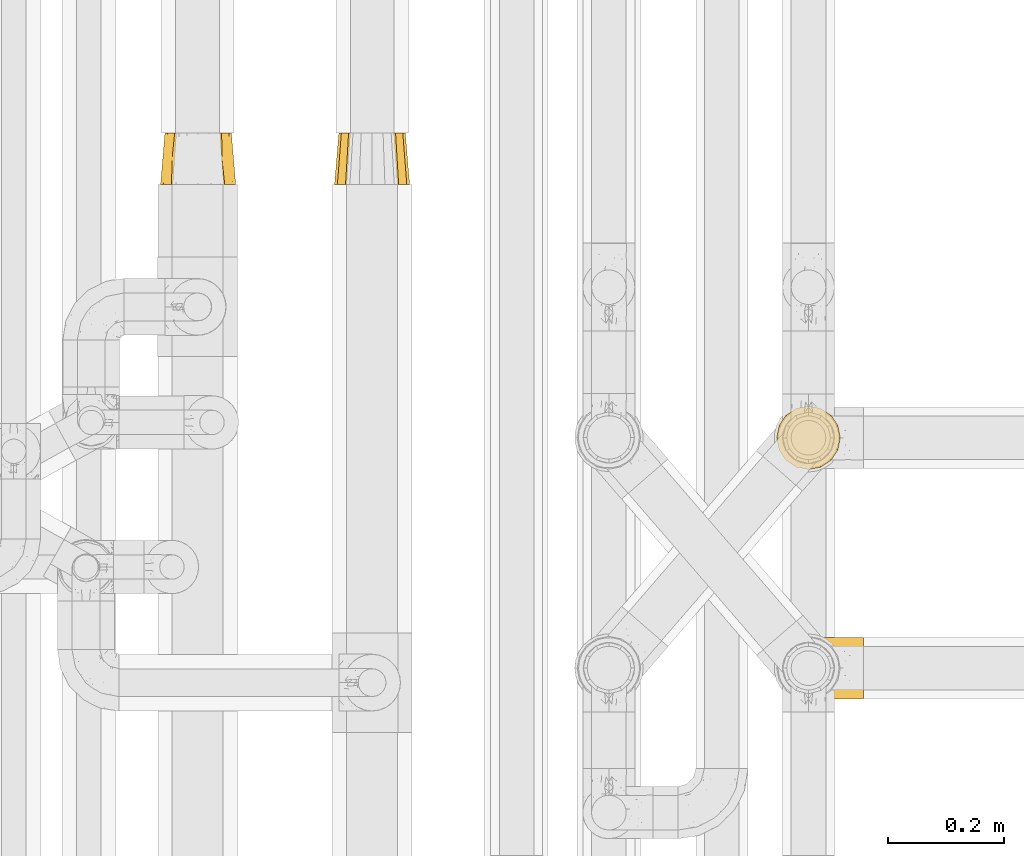
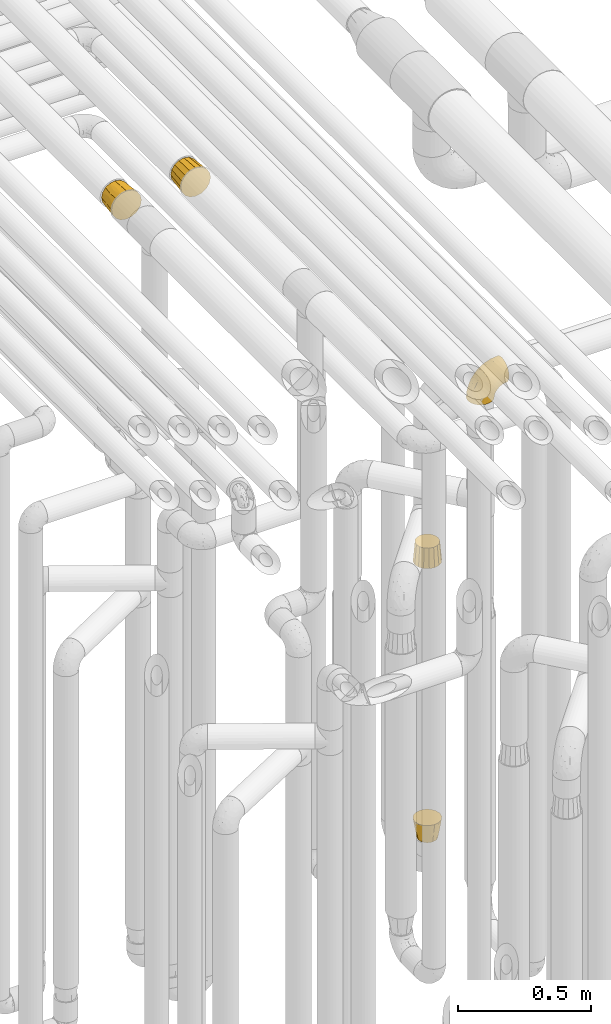
# One storey, part 233 of 827: 5 coverings.
"""IFC2X3 building model written with IfcOpenShell, lengths in millimetres."""

import ifcopenshell
import ifcopenshell.guid

model = None  # the IFC model being written
_history = None  # IfcOwnerHistory: only IFC2X3 demands one
_inside = {}  # id of a spatial element -> (the spatial element, [elements in it])
_under = {}  # id of a project, library or spatial element -> (it, [spatial elements below it])
_declared = {}  # id of a project -> (the project, [libraries it declares])
_typed = {}  # id of a type object -> (the type object, [elements of that type])
_made_of = {}  # id of a material, layer set ... -> (it, [elements and type objects made of it])


def new_model(schema):
    """Start an empty IFC model of exactly this schema.

    Asked for "IFC4X3", IfcOpenShell would pick the latest addendum, in which some entities
    have other attributes; the version numbers below select the first issue.
    IFC2X3 requires an IfcOwnerHistory on every rooted entity: one is made here for all.
    """
    global model, _history
    if schema == "IFC4X3":
        model = ifcopenshell.file(schema_version=(4, 3, 0, 0))
    else:
        model = ifcopenshell.file(schema=schema)
    _inside.clear()
    _under.clear()
    _declared.clear()
    _typed.clear()
    _made_of.clear()
    _history = None
    if model.schema == "IFC2X3":
        org = make("IfcOrganization", Name="unknown")
        user = make(
            "IfcPersonAndOrganization",
            ThePerson=make("IfcPerson", FamilyName="unknown"),
            TheOrganization=org,
        )
        app = make(
            "IfcApplication",
            ApplicationDeveloper=org,
            Version="unknown",
            ApplicationFullName="unknown",
            ApplicationIdentifier="unknown",
        )
        _history = make(
            "IfcOwnerHistory",
            OwningUser=user,
            OwningApplication=app,
            ChangeAction="ADDED",
            CreationDate=0,
        )
    return model


def make(cls, **values):
    """One entity of the class cls with the attributes given. An attribute that is None is left unset."""
    return model.create_entity(
        cls, **{name: value for name, value in values.items() if value is not None}
    )


def entity(cls, *values):
    """Any entity or typed value of the class cls, its attributes in the order of the schema. None: left unset."""
    e = model.create_entity(cls)
    for i, value in enumerate(values):
        if value is not None:
            e[i] = value
    return e


def rooted(cls, **values):
    """An entity with a GlobalId (a new one), such as an element, a storey or a relation."""
    return make(cls, GlobalId=ifcopenshell.guid.new(), OwnerHistory=_history, **values)


def si_unit(unit_type, name, prefix=None):
    """IfcSIUnit, for example si_unit("LENGTHUNIT", "METRE", prefix="MILLI")."""
    return make("IfcSIUnit", UnitType=unit_type, Prefix=prefix, Name=name)


def converted_unit(unit_type, name, factor, base, dimensions=None, offset=None):
    """IfcConversionBasedUnit, such as the inch: factor (a typed value) times the base unit."""
    return make(
        "IfcConversionBasedUnit"
        if offset is None
        else "IfcConversionBasedUnitWithOffset",
        ConversionOffset=offset,
        Dimensions=None
        if dimensions is None
        else entity("IfcDimensionalExponents", *dimensions),
        UnitType=unit_type,
        Name=name,
        ConversionFactor=make(
            "IfcMeasureWithUnit", ValueComponent=factor, UnitComponent=base
        ),
    )


def derived_unit(unit_type, elements):
    """IfcDerivedUnit: a product of units, each with its exponent."""
    return make(
        "IfcDerivedUnit",
        Elements=[
            make("IfcDerivedUnitElement", Unit=unit, Exponent=power)
            for unit, power in elements
        ],
        UnitType=unit_type,
    )


def assignment(units):
    """IfcUnitAssignment: the units of a project."""
    return None if units is None else make("IfcUnitAssignment", Units=units)


def point(xyz):
    """IfcCartesianPoint."""
    return None if xyz is None else make("IfcCartesianPoint", Coordinates=xyz)


def direction(xyz):
    """IfcDirection."""
    return None if xyz is None else make("IfcDirection", DirectionRatios=xyz)


def frame(location, z_axis=None, x_axis=None):
    """IfcAxis2Placement3D, a coordinate frame: its origin and axes. An axis left out is left unset."""
    return make(
        "IfcAxis2Placement3D",
        Location=point(location),
        Axis=direction(z_axis),
        RefDirection=direction(x_axis),
    )


def origin():
    """The frame at (0, 0, 0) with its axes left unset."""
    return frame((0.0, 0.0, 0.0))


def place(relative_to, where):
    """IfcLocalPlacement: puts the frame where relative to a parent placement (None: the world)."""
    return make(
        "IfcLocalPlacement", PlacementRelTo=relative_to, RelativePlacement=where
    )


def context(
    kind, dimensions, precision=None, world=None, true_north=None, identifier=None
):
    """IfcGeometricRepresentationContext, for example the 3D "Model" context."""
    return make(
        "IfcGeometricRepresentationContext",
        ContextIdentifier=identifier,
        ContextType=kind,
        CoordinateSpaceDimension=dimensions,
        Precision=precision,
        WorldCoordinateSystem=world,
        TrueNorth=true_north,
    )


def subcontext(parent, identifier, kind, view, scale=None):
    """IfcGeometricRepresentationSubContext, for example "Body" below "Model"."""
    return make(
        "IfcGeometricRepresentationSubContext",
        ContextIdentifier=identifier,
        ContextType=kind,
        ParentContext=parent,
        TargetScale=scale,
        TargetView=view,
    )


def project(units=None, contexts=None):
    """IfcProject with its units and contexts."""
    return rooted(
        "IfcProject",
        Name="project",
        RepresentationContexts=contexts,
        UnitsInContext=assignment(units),
    )


def spatial(cls, under=None, at=None, **own):
    """A site, building, storey or space (cls), placed at a placement, below another one or the project."""
    s = rooted(cls, ObjectPlacement=at, **own)
    if under is not None:
        _under.setdefault(under.id(), (under, []))[1].append(s)
    return s


def faces_of(points, faces, orient=None, outer=None):
    """IfcFace entities. A face is a list of loops; a loop is a list of indices into points, from 0.

    orient and outer hold one flag for each loop. By default every Orientation is true, the
    first loop of a face is its IfcFaceOuterBound and the others are IfcFaceBound.
    """
    made = []
    for i, loops in enumerate(faces):
        bounds = []
        for j, loop in enumerate(loops):
            is_outer = j == 0 if outer is None else outer[i][j]
            bounds.append(
                make(
                    "IfcFaceOuterBound" if is_outer else "IfcFaceBound",
                    Bound=make("IfcPolyLoop", Polygon=[points[k] for k in loop]),
                    Orientation=True if orient is None else orient[i][j],
                )
            )
        made.append(make("IfcFace", Bounds=bounds))
    return made


def faceted_brep(points, faces, orient=None, outer=None, voids=None):
    """IfcFacetedBrep: a solid bounded by flat faces; with voids (closed shells), ...WithVoids."""
    shared = [point(p) for p in points]
    hull = make("IfcClosedShell", CfsFaces=faces_of(shared, faces, orient, outer))
    if voids is None:
        return make("IfcFacetedBrep", Outer=hull)
    return make(
        "IfcFacetedBrepWithVoids",
        Outer=hull,
        Voids=[
            make(cls, CfsFaces=faces_of(shared, fs, o, b)) for cls, fs, o, b in voids
        ],
    )


def shape(context_of_items, identifier, shape_type, items):
    """IfcShapeRepresentation: the items that make up one representation, for example the "Body"."""
    return make(
        "IfcShapeRepresentation",
        ContextOfItems=context_of_items,
        RepresentationIdentifier=identifier,
        RepresentationType=shape_type,
        Items=items,
    )


def made_of(thing, what):
    """Note that an element or type object is made of a material, layer set ...; save() writes the relation."""
    if what is not None:
        _made_of.setdefault(what.id(), (what, []))[1].append(thing)
    return thing


def element(
    cls,
    number,
    at=None,
    inside=None,
    cuts=None,
    type_object=None,
    material=None,
    context=None,
    identifier="Body",
    shape_type=None,
    held_by="IfcProductDefinitionShape",
    body=None,
    shapes=None,
    **own,
):
    """One element of the class cls, such as IfcWall. Its Tag is "e" and its number.

    at: its placement. inside: the storey or other place that contains it. cuts: it is an
    opening in that element (IfcRelVoidsElement). A single representation is given by context,
    identifier, shape_type and body (its items); several are given by shapes. held_by: the class
    of the entity that holds the representations. save() writes the other relations.
    """
    e = rooted(cls, Tag="e%d" % number, ObjectPlacement=at, **own)
    if body is not None:
        shapes = [shape(context, identifier, shape_type, body)]
    if shapes is not None:
        e.Representation = make(held_by, Representations=shapes)
    if inside is not None:
        _inside.setdefault(inside.id(), (inside, []))[1].append(e)
    if cuts is not None:
        rooted(
            "IfcRelVoidsElement", RelatingBuildingElement=cuts, RelatedOpeningElement=e
        )
    if type_object is not None:
        _typed.setdefault(type_object.id(), (type_object, []))[1].append(e)
    return made_of(e, material)


def aggregate(whole, parts):
    """IfcRelAggregates: a whole, such as a stair, and the parts it consists of."""
    return rooted("IfcRelAggregates", RelatingObject=whole, RelatedObjects=parts)


def save(model, path):
    """Write the relations noted so far, then the file.

    IfcRelAggregates (storeys below a building ...), IfcRelContainedInSpatialStructure (elements
    in a storey), IfcRelDefinesByType, IfcRelAssociatesMaterial and IfcRelDeclares: one each for
    every whole, place, type object, material and project.
    """
    for whole, parts in _under.values():
        aggregate(whole, parts)
    for where, things in _inside.values():
        rooted(
            "IfcRelContainedInSpatialStructure",
            RelatedElements=things,
            RelatingStructure=where,
        )
    for kind, things in _typed.values():
        rooted("IfcRelDefinesByType", RelatedObjects=things, RelatingType=kind)
    for what, things in _made_of.values():
        rooted("IfcRelAssociatesMaterial", RelatedObjects=things, RelatingMaterial=what)
    for by, libraries in _declared.values():
        rooted("IfcRelDeclares", RelatingContext=by, RelatedDefinitions=libraries)
    model.write(path)


model = new_model("IFC2X3")

# Units and contexts
model_context = context("Model", 3, precision=0.01, world=origin(), true_north=direction((6.12303176911189e-17, 1.0)))
body_context = subcontext(model_context, "Body", "Model", "MODEL_VIEW")
ifc_project = project(units=[si_unit("LENGTHUNIT", "METRE", prefix="MILLI"), si_unit("AREAUNIT", "SQUARE_METRE"), si_unit("VOLUMEUNIT", "CUBIC_METRE"), converted_unit("PLANEANGLEUNIT", "DEGREE", entity("IfcRatioMeasure", 0.0174532925199433), si_unit("PLANEANGLEUNIT", "RADIAN"), dimensions=[0, 0, 0, 0, 0, 0, 0]), si_unit("MASSUNIT", "GRAM", prefix="KILO"), derived_unit("MASSDENSITYUNIT", [(si_unit("MASSUNIT", "GRAM", prefix="KILO"), 1), (si_unit("LENGTHUNIT", "METRE"), -3)]), derived_unit("MOMENTOFINERTIAUNIT", [(si_unit("LENGTHUNIT", "METRE"), 4)]), si_unit("TIMEUNIT", "SECOND"), si_unit("FREQUENCYUNIT", "HERTZ"), si_unit("THERMODYNAMICTEMPERATUREUNIT", "DEGREE_CELSIUS"), derived_unit("THERMALTRANSMITTANCEUNIT", [(si_unit("MASSUNIT", "GRAM", prefix="KILO"), 1), (si_unit("THERMODYNAMICTEMPERATUREUNIT", "KELVIN"), -1), (si_unit("TIMEUNIT", "SECOND"), -3)]), derived_unit("VOLUMETRICFLOWRATEUNIT", [(si_unit("LENGTHUNIT", "METRE"), 3), (si_unit("TIMEUNIT", "SECOND"), -1)]), derived_unit("MASSFLOWRATEUNIT", [(si_unit("MASSUNIT", "GRAM", prefix="KILO"), 1), (si_unit("TIMEUNIT", "SECOND"), -1)]), derived_unit("ROTATIONALFREQUENCYUNIT", [(si_unit("TIMEUNIT", "SECOND"), -1)]), si_unit("ELECTRICCURRENTUNIT", "AMPERE"), si_unit("ELECTRICVOLTAGEUNIT", "VOLT"), si_unit("POWERUNIT", "WATT"), si_unit("FORCEUNIT", "NEWTON", prefix="KILO"), si_unit("ILLUMINANCEUNIT", "LUX"), si_unit("LUMINOUSFLUXUNIT", "LUMEN"), si_unit("LUMINOUSINTENSITYUNIT", "CANDELA"), derived_unit("USERDEFINED", [(si_unit("MASSUNIT", "GRAM", prefix="KILO"), -1), (si_unit("LENGTHUNIT", "METRE"), -2), (si_unit("TIMEUNIT", "SECOND"), 3), (si_unit("LUMINOUSFLUXUNIT", "LUMEN"), 1)]), derived_unit("LINEARVELOCITYUNIT", [(si_unit("LENGTHUNIT", "METRE"), 1), (si_unit("TIMEUNIT", "SECOND"), -1)]), si_unit("PRESSUREUNIT", "PASCAL"), derived_unit("USERDEFINED", [(si_unit("LENGTHUNIT", "METRE"), -2), (si_unit("MASSUNIT", "GRAM", prefix="KILO"), 1), (si_unit("TIMEUNIT", "SECOND"), -2)]), derived_unit("LINEARFORCEUNIT", [(si_unit("MASSUNIT", "GRAM", prefix="KILO"), 1), (si_unit("LENGTHUNIT", "METRE"), 1), (si_unit("TIMEUNIT", "SECOND"), -2), (si_unit("LENGTHUNIT", "METRE"), -1)]), derived_unit("PLANARFORCEUNIT", [(si_unit("MASSUNIT", "GRAM", prefix="KILO"), 1), (si_unit("LENGTHUNIT", "METRE"), 1), (si_unit("TIMEUNIT", "SECOND"), -2), (si_unit("LENGTHUNIT", "METRE"), -2)])], contexts=[model_context])

# Site, building, storey
site_placement = place(None, origin())
site = spatial("IfcSite", under=ifc_project, at=site_placement, CompositionType="ELEMENT")
building_placement = place(site_placement, origin())
building = spatial("IfcBuilding", under=site, at=building_placement, CompositionType="ELEMENT")
storey_placement = place(building_placement, frame((0.0, 0.0, 28200.0)))
storey = spatial("IfcBuildingStorey", under=building, at=storey_placement, Name="08", CompositionType="ELEMENT", Elevation=28200.0)

# Coverings
covering_1_placement = place(storey_placement, frame((35852.53, 13417.7, 3483.4)))
element("IfcCovering", 1, at=covering_1_placement, inside=storey, Name=":ADSK_", ObjectType=":ADSK_", PredefinedType="INSULATION", context=body_context, shape_type="Brep", body=[
    faceted_brep([(97.95, 89.0, 113.49), (107.27, 89.0, 107.25), (113.51, 89.0, 97.93), (119.74, 89.0, 88.6), (121.93, 89.0, 77.6), (124.12, 89.0, 66.6), (121.87, 89.0, 55.32), (119.74, 89.0, 44.59), (113.51, 89.0, 35.26), (107.27, 89.0, 25.94), (97.95, 89.0, 19.7), (88.62, 89.0, 13.47), (77.62, 89.0, 11.28), (66.62, 89.0, 9.1), (55.34, 89.0, 11.34), (44.61, 89.0, 13.47), (35.28, 89.0, 19.7), (25.96, 89.0, 25.94), (19.72, 89.0, 35.26), (13.49, 89.0, 44.59), (11.3, 89.0, 55.59), (9.12, 89.0, 66.6), (11.36, 89.0, 77.87), (13.49, 89.0, 88.6), (19.72, 89.0, 97.93), (25.96, 89.0, 107.25), (35.28, 89.0, 113.49), (44.61, 89.0, 119.72), (55.61, 89.0, 121.91), (66.62, 89.0, 124.1), (77.89, 89.0, 121.85), (88.62, 89.0, 119.72), (20.63, 0.0, 112.56), (13.59, 0.0, 102.01), (6.54, 0.0, 91.47), (4.07, 0.0, 79.03), (1.6, 0.0, 66.6), (4.13, 0.0, 53.85), (6.54, 0.0, 41.72), (13.59, 0.0, 31.18), (20.63, 0.0, 20.63), (31.18, 0.0, 13.59), (41.72, 0.0, 6.54), (54.16, 0.0, 4.07), (66.6, 0.0, 1.6), (79.34, 0.0, 4.13), (91.47, 0.0, 6.54), (102.01, 0.0, 13.59), (112.56, 0.0, 20.63), (119.6, 0.0, 31.18), (126.65, 0.0, 41.72), (129.12, 0.0, 54.16), (131.6, 0.0, 66.6), (129.06, 0.0, 79.34), (126.65, 0.0, 91.47), (119.6, 0.0, 102.01), (112.56, 0.0, 112.56), (102.01, 0.0, 119.6), (91.47, 0.0, 126.65), (79.03, 0.0, 129.12), (66.6, 0.0, 131.6), (53.85, 0.0, 129.06), (41.72, 0.0, 126.65), (31.18, 0.0, 119.6), (125.17, 44.5, 48.67), (119.1, 44.5, 35.04), (127.86, 44.5, 66.6), (111.82, 44.5, 25.28), (84.53, 44.5, 8.03), (98.16, 44.5, 14.1), (66.61, 44.5, 5.35), (48.68, 44.5, 8.03), (35.05, 44.5, 14.1), (25.29, 44.5, 21.38), (8.04, 44.5, 48.67), (14.11, 44.5, 35.04), (5.36, 44.5, 66.6), (8.04, 44.5, 84.52), (14.11, 44.5, 98.15), (21.39, 44.5, 107.91), (48.68, 44.5, 125.16), (35.05, 44.5, 119.09), (66.61, 44.5, 127.85), (84.53, 44.5, 125.16), (98.16, 44.5, 119.09), (107.92, 44.5, 111.81), (125.17, 44.5, 84.52), (119.1, 44.5, 98.15)], [[[0, 1, 2, 3, 4, 5, 6, 7, 8, 9, 10, 11, 12, 13, 14, 15, 16, 17, 18, 19, 20, 21, 22, 23, 24, 25, 26, 27, 28, 29, 30, 31]], [[32, 33, 34, 35, 36, 37, 38, 39, 40, 41, 42, 43, 44, 45, 46, 47, 48, 49, 50, 51, 52, 53, 54, 55, 56, 57, 58, 59, 60, 61, 62, 63]], [[64, 50, 65]], [[7, 6, 64]], [[51, 64, 66]], [[66, 6, 5]], [[52, 51, 66]], [[7, 64, 65]], [[51, 50, 64]], [[9, 8, 67]], [[68, 11, 69]], [[67, 49, 48]], [[68, 69, 46]], [[12, 68, 70]], [[67, 8, 65]], [[67, 69, 10]], [[68, 46, 45]], [[8, 7, 65]], [[45, 70, 68]], [[65, 50, 49]], [[12, 11, 68]], [[69, 11, 10]], [[67, 47, 69]], [[6, 66, 64]], [[67, 10, 9]], [[47, 46, 69]], [[49, 67, 65]], [[67, 48, 47]], [[70, 45, 44]], [[13, 12, 70]], [[71, 42, 72]], [[15, 14, 71]], [[43, 71, 70]], [[70, 14, 13]], [[44, 43, 70]], [[15, 71, 72]], [[43, 42, 71]], [[17, 16, 73]], [[74, 19, 75]], [[73, 41, 40]], [[74, 75, 38]], [[20, 74, 76]], [[73, 16, 72]], [[73, 75, 18]], [[74, 38, 37]], [[16, 15, 72]], [[37, 76, 74]], [[72, 42, 41]], [[20, 19, 74]], [[75, 19, 18]], [[73, 39, 75]], [[14, 70, 71]], [[73, 18, 17]], [[39, 38, 75]], [[41, 73, 72]], [[73, 40, 39]], [[76, 37, 36]], [[21, 20, 76]], [[77, 34, 78]], [[23, 22, 77]], [[35, 77, 76]], [[76, 22, 21]], [[36, 35, 76]], [[23, 77, 78]], [[35, 34, 77]], [[25, 24, 79]], [[80, 27, 81]], [[79, 33, 32]], [[80, 81, 62]], [[28, 80, 82]], [[79, 24, 78]], [[79, 81, 26]], [[80, 62, 61]], [[24, 23, 78]], [[61, 82, 80]], [[78, 34, 33]], [[28, 27, 80]], [[81, 27, 26]], [[79, 63, 81]], [[22, 76, 77]], [[79, 26, 25]], [[63, 62, 81]], [[33, 79, 78]], [[79, 32, 63]], [[82, 61, 60]], [[29, 28, 82]], [[83, 58, 84]], [[31, 30, 83]], [[59, 83, 82]], [[82, 30, 29]], [[60, 59, 82]], [[31, 83, 84]], [[59, 58, 83]], [[1, 0, 85]], [[86, 3, 87]], [[85, 57, 56]], [[86, 87, 54]], [[4, 86, 66]], [[85, 0, 84]], [[85, 87, 2]], [[86, 54, 53]], [[0, 31, 84]], [[53, 66, 86]], [[84, 58, 57]], [[4, 3, 86]], [[87, 3, 2]], [[85, 55, 87]], [[30, 82, 83]], [[85, 2, 1]], [[55, 54, 87]], [[57, 85, 84]], [[85, 56, 55]], [[66, 53, 52]], [[5, 4, 66]]]),
])
covering_2_placement = place(storey_placement, frame((36153.44, 13417.7, 3483.4)))
element("IfcCovering", 2, at=covering_2_placement, inside=storey, Name=":ADSK_", ObjectType=":ADSK_", PredefinedType="INSULATION", context=body_context, shape_type="Brep", body=[
    faceted_brep([(41.72, 0.0, 126.65), (31.18, 0.0, 119.6), (20.63, 0.0, 112.56), (13.59, 0.0, 102.01), (6.54, 0.0, 91.47), (4.96, 0.0, 83.51), (1.6, 0.0, 66.6), (4.96, 0.0, 49.68), (6.54, 0.0, 41.72), (13.59, 0.0, 31.18), (20.63, 0.0, 20.63), (31.18, 0.0, 13.59), (41.72, 0.0, 6.54), (49.68, 0.0, 4.96), (66.6, 0.0, 1.6), (83.51, 0.0, 4.96), (91.47, 0.0, 6.54), (102.01, 0.0, 13.59), (112.56, 0.0, 20.63), (119.6, 0.0, 31.18), (126.65, 0.0, 41.72), (128.23, 0.0, 49.68), (131.6, 0.0, 66.6), (128.23, 0.0, 83.51), (126.65, 0.0, 91.47), (119.6, 0.0, 102.01), (112.56, 0.0, 112.56), (102.01, 0.0, 119.6), (91.47, 0.0, 126.65), (83.51, 0.0, 128.23), (66.6, 0.0, 131.6), (49.68, 0.0, 128.23), (88.6, 89.0, 119.72), (97.93, 89.0, 113.49), (107.25, 89.0, 107.25), (113.49, 89.0, 97.93), (119.72, 89.0, 88.6), (121.91, 89.0, 77.6), (124.1, 89.0, 66.6), (121.91, 89.0, 55.59), (119.72, 89.0, 44.59), (113.49, 89.0, 35.26), (107.25, 89.0, 25.94), (97.93, 89.0, 19.7), (88.6, 89.0, 13.47), (77.6, 89.0, 11.28), (66.6, 89.0, 9.1), (55.59, 89.0, 11.28), (44.59, 89.0, 13.47), (35.26, 89.0, 19.7), (25.94, 89.0, 25.94), (19.7, 89.0, 35.26), (13.47, 89.0, 44.59), (11.28, 89.0, 55.59), (9.1, 89.0, 66.6), (11.28, 89.0, 77.6), (13.47, 89.0, 88.6), (19.7, 89.0, 97.93), (25.94, 89.0, 107.25), (35.26, 89.0, 113.49), (44.59, 89.0, 119.72), (55.59, 89.0, 121.91), (66.6, 89.0, 124.1), (77.6, 89.0, 121.91)], [[[0, 1, 2, 3, 4, 5, 6, 7, 8, 9, 10, 11, 12, 13, 14, 15, 16, 17, 18, 19, 20, 21, 22, 23, 24, 25, 26, 27, 28, 29, 30, 31]], [[32, 33, 34, 35, 36, 37, 38, 39, 40, 41, 42, 43, 44, 45, 46, 47, 48, 49, 50, 51, 52, 53, 54, 55, 56, 57, 58, 59, 60, 61, 62, 63]], [[9, 8, 52, 51, 50, 10]], [[48, 12, 11, 10, 50, 49]], [[52, 8, 7, 6, 54, 53]], [[47, 46, 14, 13, 12, 48]], [[17, 16, 44, 43, 42, 18]], [[40, 20, 19, 18, 42, 41]], [[44, 16, 15, 14, 46, 45]], [[39, 38, 22, 21, 20, 40]], [[25, 24, 36, 35, 34, 26]], [[32, 28, 27, 26, 34, 33]], [[36, 24, 23, 22, 38, 37]], [[63, 62, 30, 29, 28, 32]], [[1, 0, 60, 59, 58, 2]], [[56, 4, 3, 2, 58, 57]], [[60, 0, 31, 30, 62, 61]], [[55, 54, 6, 5, 4, 56]]]),
])
covering_3_placement = place(storey_placement, frame((36918.44, 12923.05, 540.0)))
element("IfcCovering", 3, at=covering_3_placement, inside=storey, Name=":ADSK_", ObjectType=":ADSK_", PredefinedType="INSULATION", context=body_context, shape_type="Brep", body=[
    faceted_brep([(17.7, 95.49, 89.0), (11.74, 86.56, 89.0), (5.78, 77.64, 89.0), (3.69, 67.12, 89.0), (1.6, 56.6, 89.0), (3.48, 47.14, 89.0), (5.78, 35.55, 89.0), (11.74, 26.63, 89.0), (17.7, 17.7, 89.0), (26.63, 11.74, 89.0), (35.55, 5.78, 89.0), (46.07, 3.69, 89.0), (56.6, 1.6, 89.0), (66.05, 3.48, 89.0), (77.64, 5.78, 89.0), (86.56, 11.74, 89.0), (95.49, 17.7, 89.0), (101.45, 26.63, 89.0), (107.41, 35.55, 89.0), (109.5, 46.07, 89.0), (111.6, 56.6, 89.0), (109.72, 66.05, 89.0), (107.41, 77.64, 89.0), (101.45, 86.56, 89.0), (95.49, 95.49, 89.0), (86.56, 101.45, 89.0), (77.64, 107.41, 89.0), (67.12, 109.5, 89.0), (56.6, 111.6, 89.0), (47.14, 109.72, 89.0), (35.55, 107.41, 89.0), (26.63, 101.45, 89.0), (21.95, 76.6, 0.0), (29.27, 83.92, 0.0), (36.6, 91.24, 0.0), (46.6, 93.92, 0.0), (56.6, 96.6, 0.0), (66.6, 93.92, 0.0), (76.6, 91.24, 0.0), (83.92, 83.92, 0.0), (91.24, 76.6, 0.0), (93.92, 66.6, 0.0), (96.6, 56.6, 0.0), (93.92, 46.6, 0.0), (91.24, 36.6, 0.0), (83.92, 29.27, 0.0), (76.6, 21.95, 0.0), (66.6, 19.27, 0.0), (56.6, 16.6, 0.0), (46.6, 19.27, 0.0), (36.6, 21.95, 0.0), (29.27, 29.27, 0.0), (21.95, 36.6, 0.0), (19.27, 46.6, 0.0), (16.6, 56.6, 0.0), (19.27, 66.6, 0.0), (9.78, 56.6, 40.46), (36.0, 13.92, 43.84), (27.68, 18.91, 44.5), (8.41, 56.6, 48.54), (10.47, 43.11, 47.81), (14.34, 33.93, 47.15), (44.73, 10.45, 45.38), (20.49, 25.73, 44.5), (56.6, 8.41, 48.54), (56.6, 9.78, 40.46), (99.27, 36.0, 43.84), (94.28, 27.68, 44.5), (70.08, 10.47, 47.81), (79.26, 14.34, 47.15), (102.74, 44.73, 45.38), (87.46, 20.49, 44.5), (104.78, 56.6, 48.54), (103.41, 56.6, 40.46), (77.19, 99.27, 43.84), (85.51, 94.28, 44.5), (102.72, 70.08, 47.81), (98.85, 79.26, 47.15), (68.46, 102.74, 45.38), (92.7, 87.46, 44.5), (56.6, 104.78, 48.54), (56.6, 103.41, 40.46), (13.92, 77.19, 43.84), (18.91, 85.51, 44.5), (43.11, 102.72, 47.81), (33.93, 98.85, 47.15), (10.45, 68.46, 45.38), (25.73, 92.7, 44.5)], [[[0, 1, 2, 3, 4, 5, 6, 7, 8, 9, 10, 11, 12, 13, 14, 15, 16, 17, 18, 19, 20, 21, 22, 23, 24, 25, 26, 27, 28, 29, 30, 31]], [[32, 33, 34, 35, 36, 37, 38, 39, 40, 41, 42, 43, 44, 45, 46, 47, 48, 49, 50, 51, 52, 53, 54, 55]], [[53, 56, 54]], [[57, 58, 50]], [[5, 4, 59, 56]], [[56, 60, 5]], [[61, 6, 60]], [[58, 51, 50]], [[62, 49, 48]], [[51, 58, 63]], [[8, 63, 58]], [[9, 57, 10]], [[6, 5, 60]], [[60, 56, 53]], [[61, 53, 52]], [[51, 63, 52]], [[63, 7, 61]], [[60, 53, 61]], [[7, 6, 61]], [[57, 9, 58]], [[7, 63, 8]], [[52, 63, 61]], [[62, 57, 49]], [[64, 11, 62]], [[62, 48, 65, 64]], [[57, 50, 49]], [[57, 62, 10]], [[64, 12, 11]], [[9, 8, 58]], [[10, 62, 11]], [[47, 65, 48]], [[66, 67, 44]], [[13, 12, 64, 65]], [[65, 68, 13]], [[69, 14, 68]], [[67, 45, 44]], [[70, 43, 42]], [[45, 67, 71]], [[16, 71, 67]], [[17, 66, 18]], [[14, 13, 68]], [[68, 65, 47]], [[69, 47, 46]], [[45, 71, 46]], [[71, 15, 69]], [[68, 47, 69]], [[15, 14, 69]], [[66, 17, 67]], [[15, 71, 16]], [[46, 71, 69]], [[70, 66, 43]], [[72, 19, 70]], [[70, 42, 73, 72]], [[66, 44, 43]], [[66, 70, 18]], [[72, 20, 19]], [[17, 16, 67]], [[18, 70, 19]], [[41, 73, 42]], [[74, 75, 38]], [[21, 20, 72, 73]], [[73, 76, 21]], [[77, 22, 76]], [[75, 39, 38]], [[78, 37, 36]], [[39, 75, 79]], [[24, 79, 75]], [[25, 74, 26]], [[22, 21, 76]], [[76, 73, 41]], [[77, 41, 40]], [[39, 79, 40]], [[79, 23, 77]], [[76, 41, 77]], [[23, 22, 77]], [[74, 25, 75]], [[23, 79, 24]], [[40, 79, 77]], [[78, 74, 37]], [[80, 27, 78]], [[78, 36, 81, 80]], [[74, 38, 37]], [[74, 78, 26]], [[80, 28, 27]], [[25, 24, 75]], [[26, 78, 27]], [[35, 81, 36]], [[82, 83, 32]], [[29, 28, 80, 81]], [[81, 84, 29]], [[85, 30, 84]], [[83, 33, 32]], [[86, 55, 54]], [[33, 83, 87]], [[0, 87, 83]], [[1, 82, 2]], [[30, 29, 84]], [[84, 81, 35]], [[85, 35, 34]], [[33, 87, 34]], [[87, 31, 85]], [[84, 35, 85]], [[31, 30, 85]], [[82, 1, 83]], [[31, 87, 0]], [[34, 87, 85]], [[86, 82, 55]], [[59, 3, 86]], [[86, 54, 56, 59]], [[82, 32, 55]], [[82, 86, 2]], [[59, 4, 3]], [[1, 0, 83]], [[2, 86, 3]]]),
])
covering_4_placement = place(storey_placement, frame((36918.44, 12923.05, 1811.0)))
element("IfcCovering", 4, at=covering_4_placement, inside=storey, Name=":ADSK_", ObjectType=":ADSK_", PredefinedType="INSULATION", context=body_context, shape_type="Brep", body=[
    faceted_brep([(56.6, 104.1, 89.0), (47.51, 102.29, 89.0), (38.42, 100.48, 89.0), (30.71, 95.33, 89.0), (23.01, 90.18, 89.0), (17.86, 82.48, 89.0), (12.71, 74.77, 89.0), (10.9, 65.68, 89.0), (9.1, 56.6, 89.0), (10.9, 47.51, 89.0), (12.71, 38.42, 89.0), (17.86, 30.71, 89.0), (23.01, 23.01, 89.0), (30.71, 17.86, 89.0), (38.42, 12.71, 89.0), (47.51, 10.9, 89.0), (56.6, 9.1, 89.0), (65.68, 10.9, 89.0), (74.77, 12.71, 89.0), (82.48, 17.86, 89.0), (90.18, 23.01, 89.0), (95.33, 30.71, 89.0), (100.48, 38.42, 89.0), (102.29, 47.51, 89.0), (104.1, 56.6, 89.0), (102.29, 65.68, 89.0), (100.48, 74.77, 89.0), (95.33, 82.48, 89.0), (90.18, 90.18, 89.0), (82.48, 95.33, 89.0), (74.77, 100.48, 89.0), (65.68, 102.29, 89.0), (77.64, 5.78, 0.0), (69.69, 4.2, 0.0), (56.6, 1.6, 0.0), (43.51, 4.2, 0.0), (35.55, 5.78, 0.0), (26.63, 11.74, 0.0), (17.7, 17.7, 0.0), (11.74, 26.63, 0.0), (5.78, 35.55, 0.0), (4.2, 43.51, 0.0), (1.6, 56.6, 0.0), (4.2, 69.69, 0.0), (5.78, 77.64, 0.0), (11.74, 86.56, 0.0), (17.7, 95.49, 0.0), (26.63, 101.45, 0.0), (35.55, 107.41, 0.0), (43.51, 108.99, 0.0), (56.6, 111.6, 0.0), (69.69, 108.99, 0.0), (77.64, 107.41, 0.0), (86.56, 101.45, 0.0), (95.49, 95.49, 0.0), (101.45, 86.56, 0.0), (107.41, 77.64, 0.0), (108.99, 69.69, 0.0), (111.6, 56.6, 0.0), (108.99, 43.51, 0.0), (107.41, 35.55, 0.0), (101.45, 26.63, 0.0), (95.49, 17.7, 0.0), (86.56, 11.74, 0.0)], [[[0, 1, 2, 3, 4, 5, 6, 7, 8, 9, 10, 11, 12, 13, 14, 15, 16, 17, 18, 19, 20, 21, 22, 23, 24, 25, 26, 27, 28, 29, 30, 31]], [[32, 33, 34, 35, 36, 37, 38, 39, 40, 41, 42, 43, 44, 45, 46, 47, 48, 49, 50, 51, 52, 53, 54, 55, 56, 57, 58, 59, 60, 61, 62, 63]], [[6, 44, 43, 42, 8, 7]], [[5, 4, 46, 45, 44, 6]], [[1, 0, 50, 49, 48, 2]], [[4, 3, 2, 48, 47, 46]], [[14, 36, 35, 34, 16, 15]], [[13, 12, 38, 37, 36, 14]], [[9, 8, 42, 41, 40, 10]], [[12, 11, 10, 40, 39, 38]], [[22, 60, 59, 58, 24, 23]], [[21, 20, 62, 61, 60, 22]], [[17, 16, 34, 33, 32, 18]], [[20, 19, 18, 32, 63, 62]], [[30, 52, 51, 50, 0, 31]], [[29, 28, 54, 53, 52, 30]], [[25, 24, 58, 57, 56, 26]], [[28, 27, 26, 56, 55, 54]]]),
])
covering_5_placement = place(storey_placement, frame((36920.39, 12526.53, 2803.31)))
element("IfcCovering", 5, at=covering_5_placement, inside=storey, Name=":ADSK_", ObjectType=":ADSK_", PredefinedType="INSULATION", context=body_context, shape_type="Brep", body=[
    faceted_brep([(149.65, 107.7, 96.6), (149.65, 106.36, 108.41), (149.65, 102.44, 119.62), (149.65, 96.11, 129.68), (149.65, 87.71, 138.08), (149.65, 77.65, 144.4), (149.65, 66.44, 148.32), (149.65, 54.65, 149.65), (149.65, 42.84, 148.31), (149.65, 31.62, 144.39), (149.65, 21.56, 138.06), (149.65, 13.16, 129.66), (149.65, 6.84, 119.6), (149.65, 2.92, 108.39), (149.65, 1.6, 96.6), (149.65, 2.93, 84.79), (149.65, 6.85, 73.57), (149.65, 13.18, 63.51), (149.65, 21.58, 55.11), (149.65, 31.64, 48.79), (149.65, 42.85, 44.87), (149.65, 54.65, 43.55), (149.65, 66.46, 44.88), (149.65, 77.67, 48.8), (149.65, 87.73, 55.13), (149.65, 96.13, 63.53), (149.65, 102.45, 73.59), (149.65, 106.37, 84.8), (105.89, 40.91, 1.6), (100.59, 28.12, 1.6), (92.16, 17.13, 1.6), (81.17, 8.7, 1.6), (68.38, 3.4, 1.6), (54.65, 1.6, 1.6), (40.91, 3.4, 1.6), (28.12, 8.7, 1.6), (17.13, 17.13, 1.6), (8.7, 28.12, 1.6), (3.4, 40.91, 1.6), (1.6, 54.65, 1.6), (3.4, 68.38, 1.6), (8.7, 81.17, 1.6), (17.13, 92.16, 1.6), (28.12, 100.59, 1.6), (40.91, 105.89, 1.6), (54.65, 107.7, 1.6), (68.38, 105.89, 1.6), (81.17, 100.59, 1.6), (92.16, 92.16, 1.6), (100.59, 81.17, 1.6), (105.89, 68.38, 1.6), (107.7, 54.65, 1.6), (14.05, 85.53, 27.97), (9.45, 73.42, 37.09), (22.36, 83.77, 58.27), (4.7, 64.22, 27.13), (6.64, 54.65, 39.91), (81.47, 96.72, 109.11), (56.83, 93.36, 94.41), (64.02, 84.47, 110.94), (34.04, 71.37, 89.69), (21.43, 54.65, 75.62), (44.96, 54.65, 106.28), (49.8, 103.47, 60.12), (35.43, 100.91, 41.41), (42.1, 99.1, 63.22), (43.59, 105.43, 32.05), (57.88, 106.79, 52.13), (91.8, 89.81, 123.27), (88.01, 79.59, 129.32), (115.65, 81.29, 138.3), (18.94, 74.01, 62.95), (12.83, 64.14, 55.89), (24.96, 94.75, 37.4), (111.33, 54.65, 144.6), (113.8, 70.74, 142.66), (60.89, 68.3, 117.85), (86.24, 66.05, 134.01), (65.84, 100.73, 89.25), (124.58, 106.78, 103.34), (121.36, 103.6, 113.52), (72.79, 107.7, 57.43), (66.04, 107.7, 44.19), (59.29, 107.7, 30.95), (73.26, 106.07, 77.98), (121.69, 90.59, 132.66), (109.82, 97.43, 121.52), (40.11, 84.51, 86.93), (36.57, 93.3, 68.4), (93.81, 107.7, 78.45), (83.3, 107.7, 67.94), (136.6, 107.7, 94.53), (120.29, 107.7, 91.95), (99.11, 106.79, 93.36), (107.05, 107.7, 85.2), (91.12, 103.47, 101.45), (75.62, 54.65, 129.81), (56.97, 107.7, 16.27), (126.65, 76.99, 42.46), (116.55, 84.28, 40.4), (120.09, 91.11, 49.71), (76.06, 106.26, 39.4), (83.69, 102.6, 31.26), (71.88, 106.08, 27.7), (66.92, 106.56, 16.7), (110.43, 105.36, 70.67), (121.31, 106.74, 81.69), (81.0, 101.59, 16.68), (113.32, 54.65, 22.57), (111.09, 54.65, 14.26), (109.14, 67.71, 17.68), (95.86, 91.36, 19.58), (99.07, 94.33, 33.49), (106.92, 87.1, 33.01), (131.39, 65.84, 40.69), (136.98, 54.65, 40.15), (128.67, 54.65, 37.93), (117.07, 68.92, 31.04), (96.39, 100.82, 45.29), (106.61, 79.83, 23.55), (103.72, 77.13, 11.36), (92.14, 105.9, 59.1), (107.13, 101.53, 57.42), (98.03, 106.72, 68.96), (88.38, 97.75, 20.38), (130.66, 103.08, 72.46), (135.45, 106.39, 83.66), (123.57, 98.1, 60.66), (137.75, 95.02, 61.01), (133.2, 86.9, 51.85), (138.8, 74.42, 46.07), (120.99, 54.65, 30.25), (84.53, 105.28, 46.65), (108.72, 92.87, 43.0), (95.86, 17.93, 19.58), (130.67, 6.22, 72.44), (109.13, 41.58, 17.67), (93.81, 1.6, 78.45), (98.02, 2.57, 68.97), (110.43, 3.94, 70.65), (131.4, 43.46, 40.69), (126.66, 32.32, 42.45), (117.08, 40.38, 31.04), (108.74, 16.44, 42.99), (96.31, 8.47, 45.18), (99.11, 15.01, 33.46), (123.58, 11.21, 60.64), (107.12, 7.78, 57.37), (72.79, 1.6, 57.43), (66.04, 1.6, 44.19), (76.07, 3.04, 39.35), (56.97, 1.6, 16.27), (66.92, 2.73, 16.7), (120.29, 1.6, 91.95), (107.05, 1.6, 85.2), (121.26, 2.55, 81.68), (84.46, 3.98, 46.68), (83.69, 6.69, 31.26), (81.0, 7.7, 16.68), (71.88, 3.21, 27.7), (137.76, 14.28, 60.99), (133.21, 22.42, 51.84), (116.58, 25.02, 40.41), (120.1, 18.18, 49.72), (138.81, 34.89, 46.06), (136.6, 1.6, 94.53), (103.72, 32.17, 11.35), (106.96, 22.23, 33.02), (135.44, 2.91, 83.65), (88.38, 11.54, 20.38), (83.3, 1.6, 67.94), (106.6, 29.46, 23.53), (92.12, 3.38, 59.12), (59.29, 1.6, 30.95), (22.36, 25.52, 58.27), (14.05, 23.76, 27.97), (24.96, 14.54, 37.4), (35.43, 8.38, 41.41), (4.71, 45.07, 27.21), (9.45, 35.87, 37.09), (11.79, 45.14, 53.2), (57.88, 2.5, 52.13), (124.57, 2.51, 103.34), (121.37, 5.68, 113.5), (91.12, 5.82, 101.45), (56.83, 15.93, 94.41), (81.48, 12.54, 109.08), (64.05, 24.81, 110.95), (99.11, 2.5, 93.36), (73.26, 3.22, 77.98), (43.59, 3.86, 32.05), (19.5, 35.85, 64.63), (91.8, 19.47, 123.25), (121.7, 18.68, 132.65), (88.04, 29.68, 129.32), (123.34, 27.95, 139.96), (60.89, 40.99, 117.85), (34.04, 37.92, 89.69), (109.85, 11.85, 121.51), (42.1, 10.19, 63.23), (65.78, 8.55, 89.17), (113.81, 38.53, 142.66), (36.57, 15.99, 68.4), (40.12, 24.79, 86.94), (49.8, 5.82, 60.12), (86.08, 40.56, 133.2)], [[[0, 1, 2, 3, 4, 5, 6, 7, 8, 9, 10, 11, 12, 13, 14, 15, 16, 17, 18, 19, 20, 21, 22, 23, 24, 25, 26, 27]], [[28, 29, 30, 31, 32, 33, 34, 35, 36, 37, 38, 39, 40, 41, 42, 43, 44, 45, 46, 47, 48, 49, 50, 51]], [[52, 53, 54]], [[55, 39, 56]], [[57, 58, 59]], [[60, 61, 62]], [[63, 64, 65]], [[66, 63, 67]], [[68, 69, 70]], [[53, 71, 54]], [[41, 40, 53]], [[53, 72, 71]], [[73, 42, 52]], [[42, 41, 52]], [[74, 6, 75]], [[69, 76, 77]], [[43, 73, 64]], [[45, 44, 66]], [[57, 78, 58]], [[1, 79, 80]], [[67, 81, 82, 83]], [[67, 84, 81]], [[2, 1, 80]], [[3, 85, 4]], [[86, 85, 3]], [[42, 73, 43]], [[6, 5, 75]], [[3, 2, 86]], [[70, 4, 85]], [[6, 74, 7]], [[68, 85, 86]], [[66, 64, 63]], [[60, 59, 87]], [[54, 87, 88]], [[76, 60, 62]], [[84, 89, 90, 81]], [[79, 0, 91, 92]], [[77, 74, 75]], [[93, 92, 94, 89]], [[80, 86, 2]], [[40, 55, 53]], [[76, 59, 60]], [[93, 84, 95]], [[76, 62, 96]], [[55, 72, 53]], [[70, 5, 4]], [[75, 70, 69]], [[78, 84, 63]], [[93, 79, 92]], [[95, 86, 80]], [[77, 76, 96]], [[59, 69, 68]], [[57, 68, 86]], [[68, 57, 59]], [[59, 58, 87]], [[76, 69, 59]], [[88, 87, 58]], [[87, 54, 71]], [[86, 95, 57]], [[78, 57, 95]], [[84, 78, 95]], [[78, 63, 65]], [[58, 78, 65]], [[54, 88, 73]], [[84, 93, 89]], [[79, 95, 80]], [[79, 93, 95]], [[0, 79, 1]], [[66, 83, 97, 45]], [[84, 67, 63]], [[83, 66, 67]], [[64, 44, 43]], [[64, 66, 44]], [[65, 73, 88]], [[53, 52, 41]], [[73, 52, 54]], [[73, 65, 64]], [[65, 88, 58]], [[39, 55, 40]], [[72, 55, 56]], [[56, 61, 72]], [[60, 72, 61]], [[72, 60, 71]], [[87, 71, 60]], [[5, 70, 75]], [[68, 70, 85]], [[74, 77, 96]], [[69, 77, 75]], [[98, 99, 100]], [[46, 45, 97]], [[101, 102, 103]], [[103, 104, 83]], [[105, 94, 106]], [[107, 103, 102]], [[108, 109, 51, 110]], [[111, 112, 113]], [[114, 115, 116]], [[47, 104, 107]], [[110, 117, 108]], [[49, 48, 111]], [[102, 118, 112]], [[119, 120, 111]], [[50, 49, 120]], [[121, 122, 118]], [[105, 123, 89]], [[124, 48, 107]], [[26, 25, 125]], [[121, 81, 90]], [[117, 119, 99]], [[27, 26, 126]], [[0, 27, 91]], [[105, 125, 127]], [[110, 51, 50]], [[25, 128, 125]], [[22, 21, 115]], [[129, 98, 100]], [[126, 91, 27]], [[128, 129, 127]], [[122, 123, 105]], [[114, 117, 98]], [[23, 22, 130]], [[24, 128, 25]], [[129, 24, 23]], [[125, 106, 126]], [[115, 114, 22]], [[130, 129, 23]], [[114, 98, 130]], [[117, 116, 131, 108]], [[99, 119, 113]], [[122, 121, 123]], [[92, 126, 106]], [[105, 127, 122]], [[132, 121, 118]], [[114, 130, 22]], [[129, 130, 98]], [[50, 120, 110]], [[129, 128, 24]], [[125, 128, 127]], [[125, 126, 26]], [[91, 126, 92]], [[105, 89, 94]], [[105, 106, 125]], [[94, 92, 106]], [[100, 122, 127]], [[118, 122, 133]], [[112, 118, 133]], [[132, 118, 102]], [[132, 102, 101]], [[81, 121, 132]], [[82, 103, 83]], [[132, 101, 81]], [[104, 47, 46]], [[124, 107, 102]], [[48, 47, 107]], [[113, 112, 133]], [[112, 111, 124]], [[99, 113, 133]], [[111, 113, 119]], [[99, 133, 100]], [[117, 99, 98]], [[122, 100, 133]], [[127, 129, 100]], [[103, 82, 101]], [[81, 101, 82]], [[112, 124, 102]], [[48, 124, 111]], [[104, 103, 107]], [[46, 97, 104]], [[111, 120, 49]], [[83, 104, 97]], [[110, 120, 119]], [[117, 110, 119]], [[116, 117, 114]], [[89, 123, 90]], [[90, 123, 121]], [[30, 29, 134]], [[17, 16, 135]], [[51, 109, 108, 136]], [[137, 138, 139]], [[140, 141, 142]], [[143, 144, 145]], [[146, 139, 147]], [[148, 149, 150]], [[151, 32, 152]], [[153, 154, 155]], [[156, 150, 157]], [[158, 157, 159]], [[108, 142, 136]], [[31, 158, 152]], [[160, 161, 18]], [[162, 163, 143]], [[140, 142, 116]], [[142, 141, 162]], [[20, 164, 140]], [[20, 140, 115]], [[15, 14, 165]], [[160, 18, 17]], [[141, 164, 161]], [[19, 18, 161]], [[20, 115, 21]], [[28, 166, 29]], [[135, 139, 146]], [[141, 163, 162]], [[135, 146, 160]], [[143, 167, 162]], [[29, 166, 134]], [[116, 142, 108, 131]], [[165, 153, 168]], [[16, 15, 168]], [[168, 135, 16]], [[138, 147, 139]], [[158, 169, 157]], [[20, 19, 164]], [[116, 115, 140]], [[145, 167, 143]], [[135, 160, 17]], [[168, 153, 155]], [[138, 137, 170]], [[157, 144, 156]], [[147, 144, 143]], [[161, 164, 19]], [[140, 164, 141]], [[142, 171, 136]], [[136, 171, 166]], [[161, 160, 146]], [[165, 168, 15]], [[155, 139, 135]], [[139, 154, 137]], [[168, 155, 135]], [[139, 155, 154]], [[144, 147, 172]], [[163, 147, 143]], [[156, 144, 172]], [[157, 169, 145]], [[172, 148, 156]], [[173, 159, 149]], [[159, 157, 150]], [[152, 159, 173]], [[159, 152, 158]], [[31, 30, 158]], [[169, 30, 134]], [[157, 145, 144]], [[167, 134, 171]], [[134, 167, 145]], [[171, 142, 162]], [[162, 167, 171]], [[163, 141, 161]], [[161, 146, 163]], [[147, 163, 146]], [[148, 150, 156]], [[149, 159, 150]], [[30, 169, 158]], [[145, 169, 134]], [[151, 33, 32]], [[31, 152, 32]], [[152, 173, 151]], [[28, 51, 136]], [[134, 166, 171]], [[28, 136, 166]], [[138, 170, 172]], [[147, 138, 172]], [[148, 172, 170]], [[174, 175, 176]], [[35, 34, 177]], [[178, 179, 180]], [[181, 173, 149, 148]], [[182, 183, 184]], [[185, 186, 187]], [[188, 189, 137]], [[190, 33, 151, 173]], [[191, 179, 174]], [[34, 190, 177]], [[39, 38, 178]], [[192, 193, 194]], [[10, 9, 195]], [[175, 179, 37]], [[38, 37, 179]], [[35, 176, 36]], [[196, 62, 197]], [[181, 190, 173]], [[37, 36, 175]], [[183, 12, 198]], [[189, 148, 170, 137]], [[185, 199, 200]], [[9, 8, 201]], [[202, 185, 203]], [[14, 13, 182]], [[200, 184, 186]], [[183, 13, 12]], [[181, 189, 204]], [[200, 189, 184]], [[11, 198, 12]], [[187, 203, 185]], [[195, 9, 201]], [[205, 196, 194]], [[62, 61, 197]], [[186, 198, 192]], [[180, 179, 191]], [[8, 7, 74]], [[198, 193, 192]], [[193, 11, 10]], [[194, 193, 195]], [[8, 74, 201]], [[11, 193, 198]], [[205, 74, 96]], [[188, 137, 154, 153]], [[62, 196, 96]], [[56, 178, 180]], [[198, 184, 183]], [[184, 188, 182]], [[203, 197, 191]], [[205, 194, 201]], [[187, 192, 194]], [[192, 187, 186]], [[194, 196, 187]], [[197, 187, 196]], [[197, 203, 187]], [[202, 174, 176]], [[200, 186, 185]], [[184, 198, 186]], [[199, 185, 202]], [[189, 200, 204]], [[174, 202, 203]], [[176, 177, 199]], [[189, 181, 148]], [[190, 181, 204]], [[190, 204, 177]], [[190, 34, 33]], [[188, 153, 182]], [[189, 188, 184]], [[182, 153, 165, 14]], [[183, 182, 13]], [[199, 177, 204]], [[35, 177, 176]], [[176, 175, 36]], [[179, 175, 174]], [[200, 199, 204]], [[176, 199, 202]], [[203, 191, 174]], [[180, 197, 61]], [[197, 180, 191]], [[61, 56, 180]], [[39, 178, 56]], [[38, 179, 178]], [[194, 195, 201]], [[10, 195, 193]], [[74, 205, 201]], [[96, 196, 205]]]),
])

save(model, "model.ifc")
